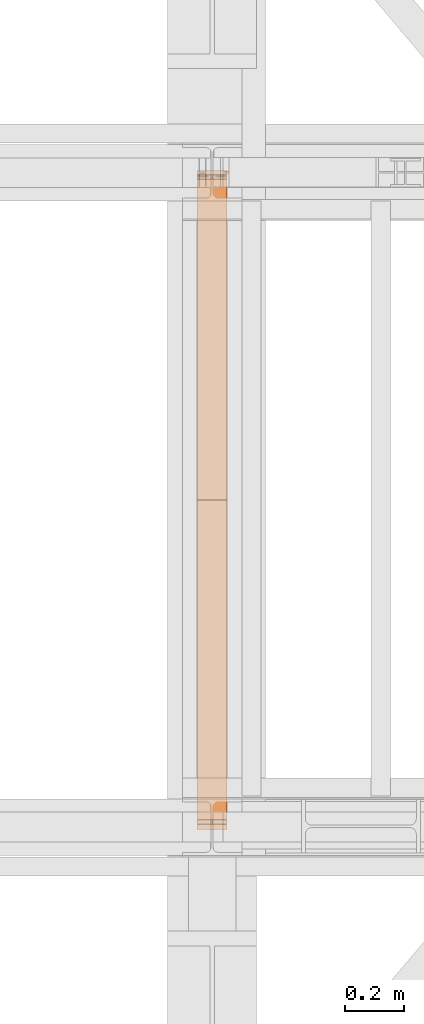
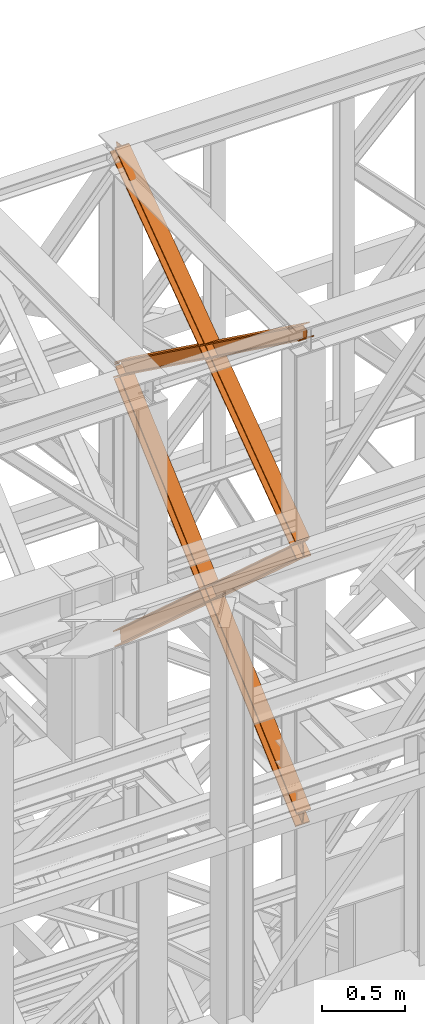
# One storey, part 168 of 208: 4 proxies.
"""IFC2X3 building model written with IfcOpenShell, lengths in millimetres."""

from ifc_helpers import new_model, entity, si_unit, converted_unit, frame, origin, origin_with_axes, place, context, subcontext, project, spatial, faceted_brep, element, save


model = new_model("IFC2X3")

# Units and contexts
model_context = context("Model", 3, precision=1e-05, world=origin())
plan_context = context("Plan", 3, precision=1e-05, world=origin())
body_context = subcontext(model_context, "Body", "Model", "MODEL_VIEW")
ifc_project = project(units=[si_unit("LENGTHUNIT", "METRE", prefix="MILLI"), converted_unit("PLANEANGLEUNIT", "DEGREE", entity("IfcPlaneAngleMeasure", 0.0174532925199433), si_unit("PLANEANGLEUNIT", "RADIAN"), dimensions=[0, 0, 0, 0, 0, 0, 0]), si_unit("AREAUNIT", "SQUARE_METRE"), si_unit("VOLUMEUNIT", "CUBIC_METRE")], contexts=[model_context, plan_context])

# Building, storey
building_placement = place(None, origin())
building = spatial("IfcBuilding", under=ifc_project, at=building_placement, CompositionType="COMPLEX")
storey_placement = place(building_placement, origin_with_axes())
storey = spatial("IfcBuildingStorey", under=building, at=storey_placement, Name="Geschoss", CompositionType="ELEMENT")

# Proxies
proxy_1_placement = place(storey_placement, frame((6542.709402308909, -16015.63876149258, 10682.68948145022), z_axis=(0.0, 0.0, 1.0), x_axis=(1.0, 0.0, 0.0)))
element("IfcBuildingElementProxy", 1, at=proxy_1_placement, inside=storey, context=body_context, shape_type="Brep", body=[
    faceted_brep([(100.0210796676656, 2245.689626284609, 118.5389832593155), (100.1143745484151, 56.20017042807194, 1708.580236273849), (100.1148393871226, 67.43957130666058, 1710.120789741106), (100.0220869572258, 2244.212677303514, 129.3143453983157), (100.0220869572258, 2244.212677303514, 129.3143453983157), (100.1148393871226, 67.43957130666058, 1710.120789741106), (0.1148394121519232, 67.45274636205431, 1710.122490249456), (0.02208754364073684, 2244.212677303513, 129.3256138365559), (0.02208754364073684, 2244.212677303513, 129.3256138365559), (0.1148394121519232, 67.45274636205431, 1710.122490249456), (0.1143745734407275, 56.21334548348023, 1708.581936782199), (0.02108025408597314, 2245.689626284609, 118.5502516975485), (0.02108025408597314, 2245.689626284609, 118.5502516975485), (0.1143745734407275, 56.21334548348023, 1708.581936782199), (47.61437456155181, 56.20708733215906, 1708.581129040735), (47.52107997553685, 2245.689626284611, 118.5448991893809), (47.52107997553685, 2245.689626284611, 118.5448991893809), (47.61437456155181, 56.20708733215906, 1708.581129040735), (47.61205046476789, 0.010082544398756, 1700.878361650326), (47.60701710203466, 7.394829104428936, 1647.001538883871), (47.51100702250551, 2260.459116064767, 10.79127802407129), (47.51100702250551, 2260.459116064767, 10.79127802407129), (47.60701710203466, 7.394829104428936, 1647.001538883871), (0.107017380585603, 7.394829104430755, 1647.006891392024), (0.01100730106008996, 2260.459116064769, 10.79663053222066), (0.01100730106008996, 2260.459116064769, 10.79663053222066), (0.107017380585603, 7.394829104430755, 1647.006891392024), (0.1060107062494353, 8.871778415476001, 1636.231526845748), (0.01000000000021828, 2261.936065039698, 0.02126843821861257), (0.01000000000021828, 2261.936065039698, 0.02126843821861257), (0.1060107062494353, 8.871778415476001, 1636.231526845748), (100.1060101198273, 8.871778415472363, 1636.220258407533), (100.0099994135744, 2261.936065039694, 0.01000000000021828), (100.0099994135744, 2261.936065039694, 0.01000000000021828), (100.1060101198273, 8.871778415472363, 1636.220258407533), (100.1070167941634, 7.394829104425298, 1646.995622953813), (100.0110067146379, 2260.459116064765, 10.78536209401318), (100.0110067146379, 2260.459116064765, 10.78536209401318), (100.1070167941634, 7.394829104425298, 1646.995622953813), (52.60701707271619, 7.394829104428936, 1647.000975461962), (52.51100699318704, 2260.459116064767, 10.79071460216255), (52.51100699318704, 2260.459116064767, 10.79071460216255), (52.60701707271619, 7.394829104428936, 1647.000975461962), (52.61205048734519, 0.01000000000021828, 1700.878355604191), (52.61437456030035, 56.20642857939311, 1708.581044015316), (52.52107994621292, 2245.689626284609, 118.5443357674758), (52.52107994621292, 2245.689626284609, 118.5443357674758), (52.61437456030035, 56.20642857939311, 1708.581044015316), (100.1143745484151, 56.20017042807194, 1708.580236273849), (100.0210796676656, 2245.689626284609, 118.5389832593155), (100.1143745484151, 56.20017042807194, 1708.580236273849), (52.61437456030035, 56.20642857939311, 1708.581044015316), (52.61205048734519, 0.01000000000021828, 1700.878355604191), (47.61205046476789, 0.010082544398756, 1700.878361650326), (47.61437456155181, 56.20708733215906, 1708.581129040735), (0.1143745734407275, 56.21334548348023, 1708.581936782199), (0.1148394121519232, 67.45274636205431, 1710.122490249456), (100.1148393871226, 67.43957130666058, 1710.120789741106), (47.61205046476789, 0.010082544398756, 1700.878361650326), (52.61205048734519, 0.01000000000021828, 1700.878355604191), (52.60701707271619, 7.394829104428936, 1647.000975461962), (100.1070167941634, 7.394829104425298, 1646.995622953813), (100.1060101198273, 8.871778415472363, 1636.220258407533), (0.1060107062494353, 8.871778415476001, 1636.231526845748), (0.107017380585603, 7.394829104430755, 1647.006891392024), (47.60701710203466, 7.394829104428936, 1647.001538883871), (100.0220869572258, 2244.212677303514, 129.3143453983157), (0.02208754364073684, 2244.212677303513, 129.3256138365559), (0.02108025408597314, 2245.689626284609, 118.5502516975485), (47.52107997553685, 2245.689626284611, 118.5448991893809), (47.51100702250551, 2260.459116064767, 10.79127802407129), (0.01100730106008996, 2260.459116064769, 10.79663053222066), (0.01000000000021828, 2261.936065039698, 0.02126843821861257), (100.0099994135744, 2261.936065039694, 0.01000000000021828), (100.0110067146379, 2260.459116064765, 10.78536209401318), (52.51100699318704, 2260.459116064767, 10.79071460216255), (52.52107994621292, 2245.689626284609, 118.5443357674758), (100.0210796676656, 2245.689626284609, 118.5389832593155)], [[[0, 1, 2, 3]], [[4, 5, 6, 7]], [[8, 9, 10, 11]], [[12, 13, 14, 15]], [[16, 17, 18, 19, 20]], [[21, 22, 23, 24]], [[25, 26, 27, 28]], [[29, 30, 31, 32]], [[33, 34, 35, 36]], [[37, 38, 39, 40]], [[41, 42, 43, 44, 45]], [[46, 47, 48, 49]], [[50, 51, 52, 53, 54, 55, 56, 57]], [[58, 59, 60, 61, 62, 63, 64, 65]], [[66, 67, 68, 69, 70, 71, 72, 73, 74, 75, 76, 77]]], orient=[[False], [False], [False], [False], [False], [False], [False], [False], [False], [False], [False], [False], [False], [False], [False]]),
])
proxy_2_placement = place(storey_placement, frame((6542.729181833694, -15971.44366069647, 10682.68296591904), z_axis=(0.0, 0.0, 1.0), x_axis=(1.0, 0.0, 0.0)))
element("IfcBuildingElementProxy", 2, at=proxy_2_placement, inside=storey, context=body_context, shape_type="Brep", body=[
    faceted_brep([(100.0217932552368, 17.74853331263148, 129.3267546407205), (100.0912677831911, 2190.182945540866, 1706.987836358048), (100.0906922275608, 2201.421092011329, 1705.446286432978), (100.0208104383473, 16.27032220023102, 118.5503583986774), (0.02179387014803069, 17.74853331263148, 129.3386776252864), (0.09126795233532903, 2190.169006714281, 1706.989636715169), (100.0912677831911, 2190.182945540866, 1706.987836358048), (100.0217932552368, 17.74853331263148, 129.3267546407205), (0.0208110532585124, 16.27032220022738, 118.5622813832288), (0.09069239670316165, 2201.407153184735, 1705.448086790095), (0.09126795233532903, 2190.169006714281, 1706.989636715169), (0.02179387014803069, 17.74853331263148, 129.3386776252864), (47.52081076117611, 16.2703222002292, 118.5566179655598), (47.59069231636022, 2201.413774127363, 1705.447231620465), (0.09069239670316165, 2201.407153184735, 1705.448086790095), (0.0208110532585124, 16.27032220022738, 118.5622813832288), (47.51098253605778, 1.488211106367089, 10.79265576491343), (47.58304941302777, 2254.773823250514, 1647.169314498546), (47.58760831105064, 2261.634760381639, 1697.186647271237), (47.59069231636022, 2201.413774127363, 1705.447231620465), (47.52081076117611, 16.2703222002292, 118.5566179655598), (0.01098282814200502, 1.488211106363451, 10.79831918255331), (0.08304970511198917, 2254.773823250511, 1647.174977916204), (47.58304941302777, 2254.773823250514, 1647.169314498546), (47.51098253605778, 1.488211106367089, 10.79265576491343), (0.01000000000021828, 0.01000000000021828, 0.02192298452973773), (0.08206748974225775, 2253.295611815232, 1636.398579320261), (0.08304970511198917, 2254.773823250511, 1647.174977916204), (0.01098282814200502, 1.488211106363451, 10.79831918255331), (100.0099993850836, 0.01000000000567525, 0.01000000000021828), (100.0820668748293, 2253.29561181524, 1636.386656335728), (0.08206748974225775, 2253.295611815232, 1636.398579320261), (0.01000000000021828, 0.01000000000021828, 0.02192298452973773), (100.010982213229, 1.488211106370727, 10.78639619803107), (100.0830490901917, 2254.773823250516, 1647.163054931671), (100.0820668748293, 2253.29561181524, 1636.386656335728), (100.0099993850836, 0.01000000000567525, 0.01000000000021828), (52.51098250530595, 1.48821110636527, 10.79205961566731), (52.58304938227957, 2254.773823250514, 1647.168718349318), (100.0830490901917, 2254.773823250516, 1647.163054931671), (100.010982213229, 1.488211106370727, 10.78639619803107), (52.52081073042791, 16.27032220022738, 118.5560218163319), (52.59069230790374, 2201.414471068691, 1705.447141602608), (52.58760833413726, 2261.634841397497, 1697.186641740611), (52.58304938227957, 2254.773823250514, 1647.168718349318), (52.51098250530595, 1.48821110636527, 10.79205961566731), (100.0208104383473, 16.27032220023102, 118.5503583986774), (100.0906922275608, 2201.421092011329, 1705.446286432978), (52.59069230790374, 2201.414471068691, 1705.447141602608), (52.52081073042791, 16.27032220022738, 118.5560218163319), (100.0912677831911, 2190.182945540866, 1706.987836358048), (0.09126795233532903, 2190.169006714281, 1706.989636715169), (0.09069239670316165, 2201.407153184735, 1705.448086790095), (47.59069231636022, 2201.413774127363, 1705.447231620465), (47.58760831105064, 2261.634760381639, 1697.186647271237), (52.58760833413726, 2261.634841397497, 1697.186641740611), (52.59069230790374, 2201.414471068691, 1705.447141602608), (100.0906922275608, 2201.421092011329, 1705.446286432978), (47.58760831105064, 2261.634760381639, 1697.186647271237), (47.58304941302777, 2254.773823250514, 1647.169314498546), (0.08304970511198917, 2254.773823250511, 1647.174977916204), (0.08206748974225775, 2253.295611815232, 1636.398579320261), (100.0820668748293, 2253.29561181524, 1636.386656335728), (100.0830490901917, 2254.773823250516, 1647.163054931671), (52.58304938227957, 2254.773823250514, 1647.168718349318), (52.58760833413726, 2261.634841397497, 1697.186641740611), (100.0208104383473, 16.27032220023102, 118.5503583986774), (52.52081073042791, 16.27032220022738, 118.5560218163319), (52.51098250530595, 1.48821110636527, 10.79205961566731), (100.010982213229, 1.488211106370727, 10.78639619803107), (100.0099993850836, 0.01000000000567525, 0.01000000000021828), (0.01000000000021828, 0.01000000000021828, 0.02192298452973773), (0.01098282814200502, 1.488211106363451, 10.79831918255331), (47.51098253605778, 1.488211106367089, 10.79265576491343), (47.52081076117611, 16.2703222002292, 118.5566179655598), (0.0208110532585124, 16.27032220022738, 118.5622813832288), (0.02179387014803069, 17.74853331263148, 129.3386776252864), (100.0217932552368, 17.74853331263148, 129.3267546407205)], [[[0, 1, 2, 3]], [[4, 5, 6, 7]], [[8, 9, 10, 11]], [[12, 13, 14, 15]], [[16, 17, 18, 19, 20]], [[21, 22, 23, 24]], [[25, 26, 27, 28]], [[29, 30, 31, 32]], [[33, 34, 35, 36]], [[37, 38, 39, 40]], [[41, 42, 43, 44, 45]], [[46, 47, 48, 49]], [[50, 51, 52, 53, 54, 55, 56, 57]], [[58, 59, 60, 61, 62, 63, 64, 65]], [[66, 67, 68, 69, 70, 71, 72, 73, 74, 75, 76, 77]]], orient=[[False], [False], [False], [False], [False], [False], [False], [False], [False], [False], [False], [False], [False], [False], [False]]),
])
proxy_3_placement = place(storey_placement, frame((6542.676947659522, -15970.94025142175, 8709.664099392032), z_axis=(0.0, 0.0, 1.0), x_axis=(1.0, 0.0, 0.0)))
element("IfcBuildingElementProxy", 3, at=proxy_3_placement, inside=storey, context=body_context, shape_type="Brep", body=[
    faceted_brep([(100.0233874223195, 2202.524047252906, 1969.026231437971), (100.204135948361, 16.74193427489081, 0.02100513656296243), (100.2031119106669, 15.34760641933463, 9.331797992270367), (100.0223627570795, 2201.129719715085, 1978.337022171885), (0.02338802788472094, 2202.524047252906, 1969.015226301408), (0.2041365539262188, 16.74193427489081, 0.01000000000021828), (100.204135948361, 16.74193427489081, 0.02100513656296243), (100.0233874223195, 2202.524047252906, 1969.026231437971), (0.02236336264650163, 2201.129719715083, 1978.32601703533), (0.2031125162320677, 15.34760641933463, 9.320792855700347), (0.2041365539262188, 16.74193427489081, 0.01000000000021828), (0.02338802788472094, 2202.524047252906, 1969.015226301408), (47.52236307500243, 2201.129719715083, 1978.331244475192), (47.703112228588, 15.34760641933463, 9.326020295562557), (0.2031125162320677, 15.34760641933463, 9.320792855700347), (0.02236336264650163, 2201.129719715083, 1978.32601703533), (47.51211642258568, 2187.186444336861, 2071.439151814395), (47.69287186516885, 1.404327856926102, 102.4339488982641), (47.703112228588, 15.34760641933463, 9.326020295562557), (47.52236307500243, 2201.129719715083, 1978.331244475192), (0.0110594602265337, 2197.850904391578, 2081.040801967907), (0.01123343514518638, 2196.096022801514, 2079.459950003524), (29.30670605184969, 2196.096022801514, 2079.463174010305), (38.62248918838486, 2197.75725418804, 2080.960688188874), (38.72759933923771, 2197.85090439158, 2081.04506277602), (47.51211642258568, 2187.186444336861, 2071.439151814395), (0.0121167102297477, 2187.186444336861, 2071.433924374533), (0.1928721528147435, 1.404327856924283, 102.4287214583947), (47.69287186516885, 1.404327856926102, 102.4339488982641), (0.01000000000021828, 2196.807553171771, 2090.667763094707), (0.01020876990332909, 2194.701695263691, 2088.770740737438), (0.01123343514518638, 2196.096022801514, 2079.459950003524), (0.0110594602265337, 2197.850904391578, 2081.040801967907), (0.0121167102297477, 2187.186444336861, 2071.433924374533), (0.01109204498970939, 2185.792116799039, 2080.744715108447), (0.1918481178254297, 0.00999999999839929, 111.7395143232407), (0.1928721528147435, 1.404327856924283, 102.4287214583947), (100.0099993944386, 2196.80755317177, 2090.67876823127), (100.0102081643418, 2194.701695263691, 2088.781745874001), (71.80672165016404, 2194.701695263691, 2088.778642041782), (62.49088072881023, 2196.362926650216, 2090.274105784663), (61.99182992716487, 2196.80755317177, 2090.674584279774), (0.01109204498970939, 2185.792116799039, 2080.744715108447), (100.0110914394281, 2185.792116799039, 2080.755720245017), (100.1918475122639, 0.00999999999839929, 111.7505194598034), (0.1918481178254297, 0.00999999999839929, 111.7395143232407), (0.01020876990332909, 2194.701695263691, 2088.770740737438), (0.01000000000021828, 2196.807553171771, 2090.667763094707), (39.12153594998199, 2196.807553171771, 2090.672067372672), (38.62250061437408, 2196.362926650216, 2090.271479036817), (29.3067174778389, 2194.701695263691, 2088.773964858256), (100.0110588546631, 2197.85090439158, 2081.051807104463), (100.01123282958, 2196.096022801514, 2079.470955140079), (100.0102081643418, 2194.701695263691, 2088.781745874001), (100.0099993944386, 2196.80755317177, 2090.67876823127), (100.0110914394281, 2185.792116799039, 2080.755720245017), (100.0121161046682, 2187.186444336861, 2071.444929511088), (100.1928715472459, 1.404327856926102, 102.4397265949574), (100.1918475122639, 0.00999999999839929, 111.7505194598034), (52.5121163923086, 2187.186444336861, 2071.439702071226), (52.69287183489359, 1.404327856924283, 102.4344991550879), (100.1928715472459, 1.404327856926102, 102.4397265949574), (100.0121161046682, 2187.186444336861, 2071.444929511088), (71.80671022417482, 2196.096022801516, 2079.467851193831), (100.01123282958, 2196.096022801514, 2079.470955140079), (100.0110588546631, 2197.85090439158, 2081.051807104463), (62.38575589440734, 2197.85090439158, 2081.047666388475), (62.49086930282101, 2197.75725418804, 2080.963314936713), (52.52236304472172, 2201.129719715083, 1978.331794732023), (52.7031121983091, 15.34760641933463, 9.326570552393605), (52.69287183489359, 1.404327856924283, 102.4344991550879), (52.5121163923086, 2187.186444336861, 2071.439702071226), (100.0223627570795, 2201.129719715085, 1978.337022171885), (100.2031119106669, 15.34760641933463, 9.331797992270367), (52.7031121983091, 15.34760641933463, 9.326570552393605), (52.52236304472172, 2201.129719715083, 1978.331794732023), (62.38575589440734, 2197.85090439158, 2081.047666388475), (100.0110588546631, 2197.85090439158, 2081.051807104463), (100.0099993944386, 2196.80755317177, 2090.67876823127), (61.99182992716487, 2196.80755317177, 2090.674584279774), (39.12153594998199, 2196.807553171771, 2090.672067372672), (0.01000000000021828, 2196.807553171771, 2090.667763094707), (0.0110594602265337, 2197.850904391578, 2081.040801967907), (38.72759933923771, 2197.85090439158, 2081.04506277602), (62.49086930282101, 2197.75725418804, 2080.963314936713), (62.38575589440734, 2197.85090439158, 2081.047666388475), (61.99182992716487, 2196.80755317177, 2090.674584279774), (62.49088072881023, 2196.362926650216, 2090.274105784663), (62.49088072881023, 2196.362926650216, 2090.274105784663), (71.80672165016404, 2194.701695263691, 2088.778642041782), (71.80671022417482, 2196.096022801516, 2079.467851193831), (62.49086930282101, 2197.75725418804, 2080.963314936713), (71.80672165016404, 2194.701695263691, 2088.778642041782), (100.0102081643418, 2194.701695263691, 2088.781745874001), (100.01123282958, 2196.096022801514, 2079.470955140079), (71.80671022417482, 2196.096022801516, 2079.467851193831), (100.0223627570795, 2201.129719715085, 1978.337022171885), (52.52236304472172, 2201.129719715083, 1978.331794732023), (52.5121163923086, 2187.186444336861, 2071.439702071226), (100.0121161046682, 2187.186444336861, 2071.444929511088), (100.0110914394281, 2185.792116799039, 2080.755720245017), (0.01109204498970939, 2185.792116799039, 2080.744715108447), (0.0121167102297477, 2187.186444336861, 2071.433924374533), (47.51211642258568, 2187.186444336861, 2071.439151814395), (47.52236307500243, 2201.129719715083, 1978.331244475192), (0.02236336264650163, 2201.129719715083, 1978.32601703533), (0.02338802788472094, 2202.524047252906, 1969.015226301408), (100.0233874223195, 2202.524047252906, 1969.026231437971), (29.30670605184969, 2196.096022801514, 2079.463174010305), (0.01123343514518638, 2196.096022801514, 2079.459950003524), (0.01020876990332909, 2194.701695263691, 2088.770740737438), (29.3067174778389, 2194.701695263691, 2088.773964858256), (29.3067174778389, 2194.701695263691, 2088.773964858256), (38.62250061437408, 2196.362926650216, 2090.271479036817), (38.62248918838486, 2197.75725418804, 2080.960688188874), (29.30670605184969, 2196.096022801514, 2079.463174010305), (38.62250061437408, 2196.362926650216, 2090.271479036817), (39.12153594998199, 2196.807553171771, 2090.672067372672), (38.72759933923771, 2197.85090439158, 2081.04506277602), (38.62248918838486, 2197.75725418804, 2080.960688188874), (100.204135948361, 16.74193427489081, 0.02100513656296243), (0.2041365539262188, 16.74193427489081, 0.01000000000021828), (0.2031125162320677, 15.34760641933463, 9.320792855700347), (47.703112228588, 15.34760641933463, 9.326020295562557), (47.69287186516885, 1.404327856926102, 102.4339488982641), (0.1928721528147435, 1.404327856924283, 102.4287214583947), (0.1918481178254297, 0.00999999999839929, 111.7395143232407), (100.1918475122639, 0.00999999999839929, 111.7505194598034), (100.1928715472459, 1.404327856926102, 102.4397265949574), (52.69287183489359, 1.404327856924283, 102.4344991550879), (52.7031121983091, 15.34760641933463, 9.326570552393605), (100.2031119106669, 15.34760641933463, 9.331797992270367)], [[[0, 1, 2, 3]], [[4, 5, 6, 7]], [[8, 9, 10, 11]], [[12, 13, 14, 15]], [[16, 17, 18, 19]], [[20, 21, 22, 23, 24]], [[25, 26, 27, 28]], [[29, 30, 31, 32]], [[33, 34, 35, 36]], [[37, 38, 39, 40, 41]], [[42, 43, 44, 45]], [[46, 47, 48, 49, 50]], [[51, 52, 53, 54]], [[55, 56, 57, 58]], [[59, 60, 61, 62]], [[63, 64, 65, 66, 67]], [[68, 69, 70, 71]], [[72, 73, 74, 75]], [[76, 77, 78, 79]], [[80, 81, 82, 83]], [[84, 85, 86, 87]], [[88, 89, 90, 91]], [[92, 93, 94, 95]], [[96, 97, 98, 99, 100, 101, 102, 103, 104, 105, 106, 107]], [[108, 109, 110, 111]], [[112, 113, 114, 115]], [[116, 117, 118, 119]], [[120, 121, 122, 123, 124, 125, 126, 127, 128, 129, 130, 131]]], orient=[[False], [False], [False], [False], [False], [False], [False], [False], [False], [False], [False], [False], [False], [False], [False], [False], [False], [False], [False], [False], [False], [False], [False], [False], [False], [False], [False], [False]]),
])
proxy_4_placement = place(storey_placement, frame((6542.73408746112, -15954.28145682049, 8709.631705441292), z_axis=(0.0, 0.0, 1.0), x_axis=(1.0, 0.0, 0.0)))
element("IfcBuildingElementProxy", 4, at=proxy_4_placement, inside=storey, context=body_context, shape_type="Brep", body=[
    faceted_brep([(100.0202537490113, 1.404418357440591, 1976.169685278082), (100.1537894349167, 2184.74959498962, 9.331916248220296), (100.1547211341531, 2183.35672227913, 0.0197810693334759), (100.0211859525844, 0.01154596052219858, 1966.857552195595), (100.0211859525844, 0.01154596052219858, 1966.857552195595), (100.1547211341531, 2183.35672227913, 0.0197810693334759), (0.1547216244507581, 2183.355176318608, 0.01000000000021828), (0.02118644288202631, 0.01000000000021828, 1966.847771126266), (0.02118644288202631, 0.01000000000021828, 1966.847771126266), (0.1547216244507581, 2183.355176318608, 0.01000000000021828), (0.1537899252161878, 2184.748049029098, 9.322135178887038), (0.02025423930899706, 1.40287239691861, 1976.159904208749), (0.02025423930899706, 1.40287239691861, 1976.159904208749), (0.1537899252161878, 2184.748049029098, 9.322135178887038), (47.65378969232734, 2184.748783360346, 9.326781186826338), (47.52025400642015, 1.403606728164959, 1976.164550216681), (47.52025400642015, 1.403606728164959, 1976.164550216681), (47.65378969232734, 2184.748783360346, 9.326781186826338), (47.64447271073732, 2198.677510471935, 102.4481330204089), (47.51093197068258, 15.33233069734524, 2069.285881041526), (47.51093197068258, 15.33233069734524, 2069.285881041526), (47.64447271073732, 2198.677510471935, 102.4481330204089), (0.1444729436279886, 2198.676776140686, 102.4434870124769), (0.01093220357506652, 15.33159636609526, 2069.281235033586), (0.01093220357506652, 15.33159636609526, 2069.281235033586), (0.1444729436279886, 2198.676776140686, 102.4434870124769), (0.1435412465452828, 2200.069648852516, 111.7556222003168), (0.01000000000021828, 16.72446876301547, 2078.593368116077), (0.01000000000021828, 16.72446876301547, 2078.593368116077), (0.1435412465452828, 2200.069648852516, 111.7556222003168), (100.1435407562476, 2200.071194813039, 111.7654032696537), (100.0099995097044, 16.72601472353745, 2078.603149185414), (100.0099995097044, 16.72601472353745, 2078.603149185414), (100.1435407562476, 2200.071194813039, 111.7654032696537), (100.1444724533303, 2198.67832210121, 102.4532680818102), (100.0109317132756, 15.33314232661905, 2069.29101610293), (100.0109317132756, 15.33314232661905, 2069.29101610293), (100.1444724533303, 2198.67832210121, 102.4532680818102), (52.64447268622098, 2198.677587769962, 102.4486220738781), (52.51093194616988, 15.33240799537089, 2069.286370094991), (52.51093194616988, 15.33240799537089, 2069.286370094991), (52.64447268622098, 2198.677587769962, 102.4486220738781), (52.653789667811, 2184.748860658372, 9.327270240288271), (52.52025398190563, 1.403684026192423, 1976.165039270154), (52.52025398190563, 1.403684026192423, 1976.165039270154), (52.653789667811, 2184.748860658372, 9.327270240288271), (100.1537894349167, 2184.74959498962, 9.331916248220296), (100.0202537490113, 1.404418357440591, 1976.169685278082), (100.0211859525844, 0.01154596052219858, 1966.857552195595), (0.02118644288202631, 0.01000000000021828, 1966.847771126266), (0.02025423930899706, 1.40287239691861, 1976.159904208749), (47.52025400642015, 1.403606728164959, 1976.164550216681), (47.51093197068258, 15.33233069734524, 2069.285881041526), (0.01093220357506652, 15.33159636609526, 2069.281235033586), (0.01000000000021828, 16.72446876301547, 2078.593368116077), (100.0099995097044, 16.72601472353745, 2078.603149185414), (100.0109317132756, 15.33314232661905, 2069.29101610293), (52.51093194616988, 15.33240799537089, 2069.286370094991), (52.52025398190563, 1.403684026192423, 1976.165039270154), (100.0202537490113, 1.404418357440591, 1976.169685278082), (100.1537894349167, 2184.74959498962, 9.331916248220296), (52.653789667811, 2184.748860658372, 9.327270240288271), (52.64447268622098, 2198.677587769962, 102.4486220738781), (100.1444724533303, 2198.67832210121, 102.4532680818102), (100.1435407562476, 2200.071194813039, 111.7654032696537), (0.1435412465452828, 2200.069648852516, 111.7556222003168), (0.1444729436279886, 2198.676776140686, 102.4434870124769), (47.64447271073732, 2198.677510471935, 102.4481330204089), (47.65378969232734, 2184.748783360346, 9.326781186826338), (0.1537899252161878, 2184.748049029098, 9.322135178887038), (0.1547216244507581, 2183.355176318608, 0.01000000000021828), (100.1547211341531, 2183.35672227913, 0.0197810693334759)], [[[0, 1, 2, 3]], [[4, 5, 6, 7]], [[8, 9, 10, 11]], [[12, 13, 14, 15]], [[16, 17, 18, 19]], [[20, 21, 22, 23]], [[24, 25, 26, 27]], [[28, 29, 30, 31]], [[32, 33, 34, 35]], [[36, 37, 38, 39]], [[40, 41, 42, 43]], [[44, 45, 46, 47]], [[48, 49, 50, 51, 52, 53, 54, 55, 56, 57, 58, 59]], [[60, 61, 62, 63, 64, 65, 66, 67, 68, 69, 70, 71]]], orient=[[False], [False], [False], [False], [False], [False], [False], [False], [False], [False], [False], [False], [False], [False]]),
])

save(model, "model.ifc")
